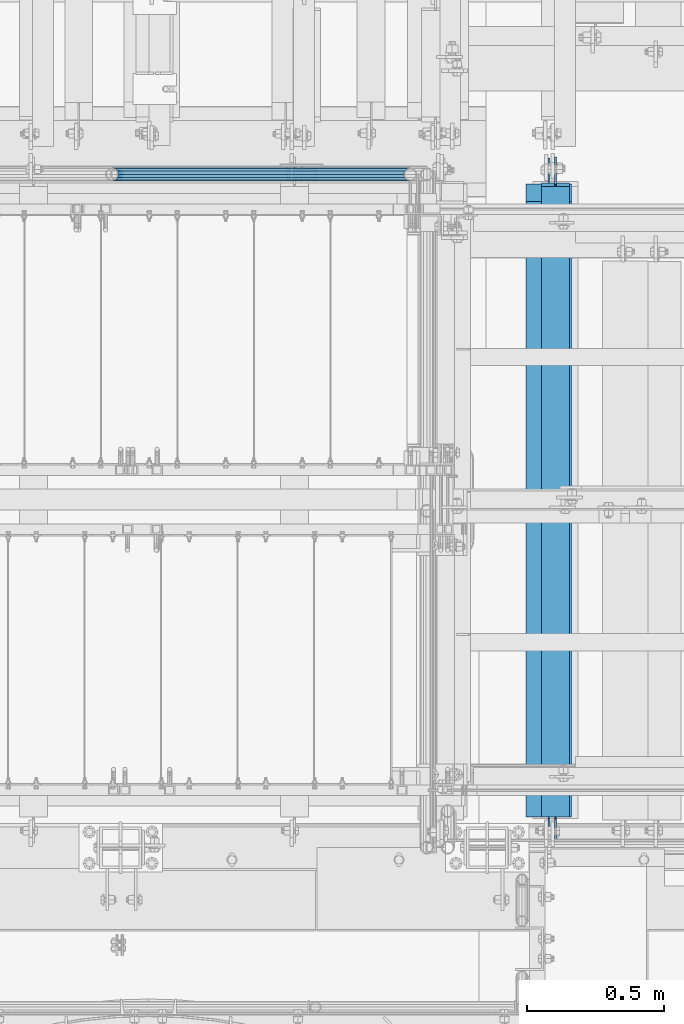
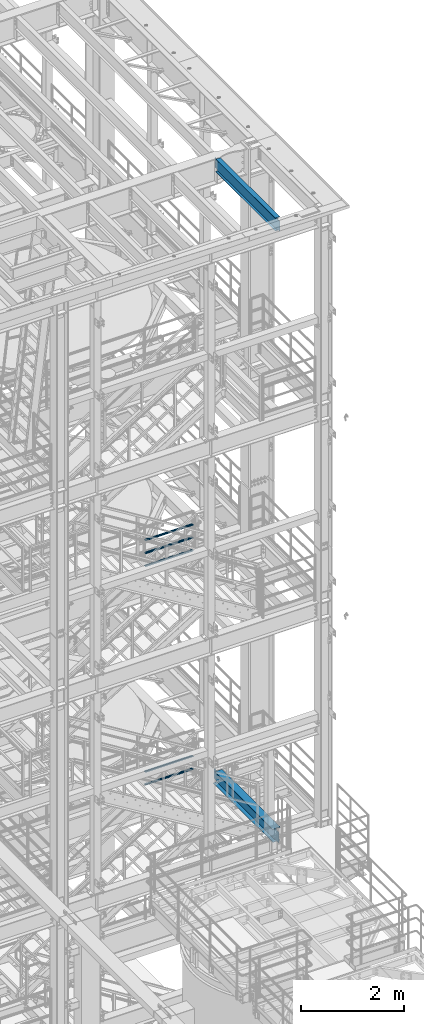
# One storey, part 986 of 1876: 7 beams, 4 elements without a shape of their own.
"""IFC2X3 building model written with IfcOpenShell, lengths in millimetres."""

import ifcopenshell
import ifcopenshell.guid

model = None  # the IFC model being written
_history = None  # IfcOwnerHistory: only IFC2X3 demands one
_inside = {}  # id of a spatial element -> (the spatial element, [elements in it])
_under = {}  # id of a project, library or spatial element -> (it, [spatial elements below it])
_declared = {}  # id of a project -> (the project, [libraries it declares])
_typed = {}  # id of a type object -> (the type object, [elements of that type])
_made_of = {}  # id of a material, layer set ... -> (it, [elements and type objects made of it])


def new_model(schema):
    """Start an empty IFC model of exactly this schema.

    Asked for "IFC4X3", IfcOpenShell would pick the latest addendum, in which some entities
    have other attributes; the version numbers below select the first issue.
    IFC2X3 requires an IfcOwnerHistory on every rooted entity: one is made here for all.
    """
    global model, _history
    if schema == "IFC4X3":
        model = ifcopenshell.file(schema_version=(4, 3, 0, 0))
    else:
        model = ifcopenshell.file(schema=schema)
    _inside.clear()
    _under.clear()
    _declared.clear()
    _typed.clear()
    _made_of.clear()
    _history = None
    if model.schema == "IFC2X3":
        org = make("IfcOrganization", Name="unknown")
        user = make(
            "IfcPersonAndOrganization",
            ThePerson=make("IfcPerson", FamilyName="unknown"),
            TheOrganization=org,
        )
        app = make(
            "IfcApplication",
            ApplicationDeveloper=org,
            Version="unknown",
            ApplicationFullName="unknown",
            ApplicationIdentifier="unknown",
        )
        _history = make(
            "IfcOwnerHistory",
            OwningUser=user,
            OwningApplication=app,
            ChangeAction="ADDED",
            CreationDate=0,
        )
    return model


def make(cls, **values):
    """One entity of the class cls with the attributes given. An attribute that is None is left unset."""
    return model.create_entity(
        cls, **{name: value for name, value in values.items() if value is not None}
    )


def rooted(cls, **values):
    """An entity with a GlobalId (a new one), such as an element, a storey or a relation."""
    return make(cls, GlobalId=ifcopenshell.guid.new(), OwnerHistory=_history, **values)


def si_unit(unit_type, name, prefix=None):
    """IfcSIUnit, for example si_unit("LENGTHUNIT", "METRE", prefix="MILLI")."""
    return make("IfcSIUnit", UnitType=unit_type, Prefix=prefix, Name=name)


def assignment(units):
    """IfcUnitAssignment: the units of a project."""
    return None if units is None else make("IfcUnitAssignment", Units=units)


def point(xyz):
    """IfcCartesianPoint."""
    return None if xyz is None else make("IfcCartesianPoint", Coordinates=xyz)


def direction(xyz):
    """IfcDirection."""
    return None if xyz is None else make("IfcDirection", DirectionRatios=xyz)


def frame(location, z_axis=None, x_axis=None):
    """IfcAxis2Placement3D, a coordinate frame: its origin and axes. An axis left out is left unset."""
    return make(
        "IfcAxis2Placement3D",
        Location=point(location),
        Axis=direction(z_axis),
        RefDirection=direction(x_axis),
    )


def origin_with_axes():
    """The frame at (0, 0, 0) with the z axis (0, 0, 1) and the x axis (1, 0, 0) written out."""
    return frame((0.0, 0.0, 0.0), z_axis=(0.0, 0.0, 1.0), x_axis=(1.0, 0.0, 0.0))


def place(relative_to, where):
    """IfcLocalPlacement: puts the frame where relative to a parent placement (None: the world)."""
    return make(
        "IfcLocalPlacement", PlacementRelTo=relative_to, RelativePlacement=where
    )


def context(
    kind, dimensions, precision=None, world=None, true_north=None, identifier=None
):
    """IfcGeometricRepresentationContext, for example the 3D "Model" context."""
    return make(
        "IfcGeometricRepresentationContext",
        ContextIdentifier=identifier,
        ContextType=kind,
        CoordinateSpaceDimension=dimensions,
        Precision=precision,
        WorldCoordinateSystem=world,
        TrueNorth=true_north,
    )


def subcontext(parent, identifier, kind, view, scale=None):
    """IfcGeometricRepresentationSubContext, for example "Body" below "Model"."""
    return make(
        "IfcGeometricRepresentationSubContext",
        ContextIdentifier=identifier,
        ContextType=kind,
        ParentContext=parent,
        TargetScale=scale,
        TargetView=view,
    )


def project(units=None, contexts=None):
    """IfcProject with its units and contexts."""
    return rooted(
        "IfcProject",
        Name="project",
        RepresentationContexts=contexts,
        UnitsInContext=assignment(units),
    )


def spatial(cls, under=None, at=None, **own):
    """A site, building, storey or space (cls), placed at a placement, below another one or the project."""
    s = rooted(cls, ObjectPlacement=at, **own)
    if under is not None:
        _under.setdefault(under.id(), (under, []))[1].append(s)
    return s


def faces_of(points, faces, orient=None, outer=None):
    """IfcFace entities. A face is a list of loops; a loop is a list of indices into points, from 0.

    orient and outer hold one flag for each loop. By default every Orientation is true, the
    first loop of a face is its IfcFaceOuterBound and the others are IfcFaceBound.
    """
    made = []
    for i, loops in enumerate(faces):
        bounds = []
        for j, loop in enumerate(loops):
            is_outer = j == 0 if outer is None else outer[i][j]
            bounds.append(
                make(
                    "IfcFaceOuterBound" if is_outer else "IfcFaceBound",
                    Bound=make("IfcPolyLoop", Polygon=[points[k] for k in loop]),
                    Orientation=True if orient is None else orient[i][j],
                )
            )
        made.append(make("IfcFace", Bounds=bounds))
    return made


def faceted_brep(points, faces, orient=None, outer=None, voids=None):
    """IfcFacetedBrep: a solid bounded by flat faces; with voids (closed shells), ...WithVoids."""
    shared = [point(p) for p in points]
    hull = make("IfcClosedShell", CfsFaces=faces_of(shared, faces, orient, outer))
    if voids is None:
        return make("IfcFacetedBrep", Outer=hull)
    return make(
        "IfcFacetedBrepWithVoids",
        Outer=hull,
        Voids=[
            make(cls, CfsFaces=faces_of(shared, fs, o, b)) for cls, fs, o, b in voids
        ],
    )


def shape(context_of_items, identifier, shape_type, items):
    """IfcShapeRepresentation: the items that make up one representation, for example the "Body"."""
    return make(
        "IfcShapeRepresentation",
        ContextOfItems=context_of_items,
        RepresentationIdentifier=identifier,
        RepresentationType=shape_type,
        Items=items,
    )


def material(Name=None, Category=None):
    """IfcMaterial."""
    return make("IfcMaterial", Name=Name, Category=Category)


def made_of(thing, what):
    """Note that an element or type object is made of a material, layer set ...; save() writes the relation."""
    if what is not None:
        _made_of.setdefault(what.id(), (what, []))[1].append(thing)
    return thing


def type_object(cls, material=None, **own):
    """A type object (cls), such as IfcWallType, which elements share."""
    return made_of(rooted(cls, **own), material)


def element(
    cls,
    number,
    at=None,
    inside=None,
    cuts=None,
    type_object=None,
    material=None,
    context=None,
    identifier="Body",
    shape_type=None,
    held_by="IfcProductDefinitionShape",
    body=None,
    shapes=None,
    **own,
):
    """One element of the class cls, such as IfcWall. Its Tag is "e" and its number.

    at: its placement. inside: the storey or other place that contains it. cuts: it is an
    opening in that element (IfcRelVoidsElement). A single representation is given by context,
    identifier, shape_type and body (its items); several are given by shapes. held_by: the class
    of the entity that holds the representations. save() writes the other relations.
    """
    e = rooted(cls, Tag="e%d" % number, ObjectPlacement=at, **own)
    if body is not None:
        shapes = [shape(context, identifier, shape_type, body)]
    if shapes is not None:
        e.Representation = make(held_by, Representations=shapes)
    if inside is not None:
        _inside.setdefault(inside.id(), (inside, []))[1].append(e)
    if cuts is not None:
        rooted(
            "IfcRelVoidsElement", RelatingBuildingElement=cuts, RelatedOpeningElement=e
        )
    if type_object is not None:
        _typed.setdefault(type_object.id(), (type_object, []))[1].append(e)
    return made_of(e, material)


def aggregate(whole, parts):
    """IfcRelAggregates: a whole, such as a stair, and the parts it consists of."""
    return rooted("IfcRelAggregates", RelatingObject=whole, RelatedObjects=parts)


def save(model, path):
    """Write the relations noted so far, then the file.

    IfcRelAggregates (storeys below a building ...), IfcRelContainedInSpatialStructure (elements
    in a storey), IfcRelDefinesByType, IfcRelAssociatesMaterial and IfcRelDeclares: one each for
    every whole, place, type object, material and project.
    """
    for whole, parts in _under.values():
        aggregate(whole, parts)
    for where, things in _inside.values():
        rooted(
            "IfcRelContainedInSpatialStructure",
            RelatedElements=things,
            RelatingStructure=where,
        )
    for kind, things in _typed.values():
        rooted("IfcRelDefinesByType", RelatedObjects=things, RelatingType=kind)
    for what, things in _made_of.values():
        rooted("IfcRelAssociatesMaterial", RelatedObjects=things, RelatingMaterial=what)
    for by, libraries in _declared.values():
        rooted("IfcRelDeclares", RelatingContext=by, RelatedDefinitions=libraries)
    model.write(path)


model = new_model("IFC2X3")

# Units and contexts
model_context = context("Model", 3, precision=1e-05, world=origin_with_axes())
body_context = subcontext(model_context, "Body", "Model", "MODEL_VIEW")
ifc_project = project(units=[si_unit("LENGTHUNIT", "METRE", prefix="MILLI"), si_unit("AREAUNIT", "SQUARE_METRE"), si_unit("VOLUMEUNIT", "CUBIC_METRE"), si_unit("MASSUNIT", "GRAM", prefix="KILO"), si_unit("TIMEUNIT", "SECOND"), si_unit("PLANEANGLEUNIT", "RADIAN"), si_unit("SOLIDANGLEUNIT", "STERADIAN"), si_unit("THERMODYNAMICTEMPERATUREUNIT", "DEGREE_CELSIUS"), si_unit("LUMINOUSINTENSITYUNIT", "LUMEN")], contexts=[model_context])

# Site, building, storey
site_placement = place(None, origin_with_axes())
site = spatial("IfcSite", under=ifc_project, at=site_placement, CompositionType="ELEMENT")
building_placement = place(site_placement, origin_with_axes())
building = spatial("IfcBuilding", under=site, at=building_placement, Name="Undefined", CompositionType="ELEMENT")
storey_placement = place(building_placement, origin_with_axes())
storey = spatial("IfcBuildingStorey", under=building, at=storey_placement, Name="Undefined", CompositionType="ELEMENT", Elevation=0.0)

# Assembly, beams
assembly_1_placement = place(storey_placement, origin_with_axes())
assembly_1 = element("IfcElementAssembly", 1, at=assembly_1_placement, inside=storey, Name="RAIL", AssemblyPlace="NOTDEFINED", PredefinedType="RIGID_FRAME")
ifc_material_1 = material()
beam_type_1 = type_object("IfcBeamType", Name="PIPE1-1/2SCH40", PredefinedType="NOTDEFINED")
beam_1_placement = place(assembly_1_placement, frame((6137.27499995291, -4654.55000114568, 13471.525), z_axis=(0.0, 0.0, 1.0), x_axis=(-1.0, 0.0, 0.0)))
beam_1 = element("IfcBeam", 2, at=beam_1_placement, type_object=beam_type_1, material=ifc_material_1, Name="RAIL", ObjectType="PIPE1-1/2SCH40", context=body_context, shape_type="Brep", body=[
    faceted_brep([(1068.12780699489, -12.0649999999996, 20.8971929933177), (1068.12780699489, -12.064999999986, 15.8661214311942), (1067.63437855703, -10.2235000000001, 17.7076214311801), (1064.89499998821, 0.0, 20.4470000000001), (1064.89499998821, 0.0, 24.1299999999992), (1067.63437855703, 10.2235000000001, 17.7076214311801), (1068.12780699489, 12.0650000000132, 15.8661214311669), (1068.12780699489, 12.0649999999996, 20.8971929933177), (1089.02499998822, 24.1300000000001, 0.0), (1076.95999998821, 20.8971929933186, 12.0650000000005), (1076.95999998821, 20.8971929933186, -12.0650000000005), (1073.77042842606, 17.7076214311801, 10.2235000000001), (1076.50980699488, 20.4470000000001, 0.0), (1073.77042842606, 17.7076214311801, -10.2235000000001), (1068.12780699489, 12.0650000000132, -15.8661214311669), (1068.12780699489, 12.0649999999996, -20.8971929933177), (1067.63437855703, 10.2235000000001, -17.7076214311801), (1064.89499998821, 0.0, -20.4470000000001), (1064.89499998821, 0.0, -24.1299999999992), (1068.12780699489, -12.064999999986, -15.8661214311942), (1068.12780699489, -12.0649999999996, -20.8971929933177), (1067.63437855703, -10.2235000000001, -17.7076214311801), (1089.02499998821, -24.1299999999865, 0.0), (1076.95999998821, -20.8971929933186, -12.0650000000005), (1076.95999998821, -20.8971929933186, 12.0650000000005), (1073.77042842609, -17.7076214311801, -10.2235000000001), (1076.50980699491, -20.4470000000001, 0.0), (1073.77042842609, -17.7076214311801, 10.2235000000001), (12.0650000000064, -20.8971929933177, -12.0649999999987), (20.8971929933249, -12.0650000000005, -20.8971929933177), (0.0, 24.1299999999992, 0.0), (12.0650000000064, 20.8971929933177, -12.0649999999987), (12.0650000000064, 20.8971929933177, 12.0649999999987), (20.8971929933249, 12.0650000000005, 20.8971929933177), (24.1300000000064, 0.0, 24.130000000001), (20.8971929933249, 12.0650000000005, -20.8971929933177), (24.1300000000063, 0.0, -24.130000000001), (24.1300000000063, 0.0, -20.4470000000001), (20.8971929933249, -12.0650000000005, -15.8661214311796), (21.3906214311868, -10.2235000000001, -17.7076214311819), (21.3906214311868, 10.2235000000001, -17.7076214311819), (20.8971929933249, 12.0650000000005, -15.8661214311796), (15.2545715621445, 17.7076214311801, -10.2235000000001), (12.5151929933249, 20.4470000000001, 0.0), (15.2545715621445, 17.7076214311801, 10.2235000000001), (20.8971929933249, 12.0650000000005, 15.8661214311796), (21.3906214311868, 10.2235000000001, 17.7076214311819), (24.1300000000064, 0.0, 20.4470000000001), (21.3906214311868, -10.2235000000001, 17.7076214311819), (20.8971929933249, -12.0650000000005, 15.8661214311796), (20.8971929933249, -12.0650000000005, 20.8971929933177), (12.0650000000064, -20.8971929933177, 12.0649999999987), (0.0, -24.1299999999992, 0.0), (15.2545715621445, -17.7076214311801, 10.2235000000001), (12.5151929933249, -20.4470000000001, 0.0), (15.2545715621445, -17.7076214311801, -10.2235000000001)], [[[0, 1, 2, 3, 4]], [[4, 3, 5, 6, 7]], [[8, 9, 10]], [[7, 6, 11, 12, 13, 14, 15, 10, 9]], [[16, 17, 18, 15, 14]], [[19, 20, 18, 17, 21]], [[22, 23, 24]], [[24, 23, 20, 19, 25, 26, 27, 1, 0]], [[28, 29, 20, 23]], [[30, 31, 32]], [[33, 34, 4, 7]], [[32, 33, 7, 9]], [[30, 32, 9, 8]], [[31, 30, 8, 10]], [[35, 31, 10, 15]], [[36, 35, 15, 18]], [[29, 36, 18, 20]], [[37, 36, 29, 38, 39]], [[40, 41, 35, 36, 37]], [[32, 31, 35, 41, 42, 43, 44, 45, 33]], [[33, 45, 46, 47, 34]], [[34, 47, 48, 49, 50]], [[34, 50, 0, 4]], [[50, 51, 24, 0]], [[51, 52, 22, 24]], [[52, 28, 23, 22]], [[51, 28, 52]], [[50, 49, 53, 54, 55, 38, 29, 28, 51]], [[55, 54, 26, 25]], [[21, 39, 38, 55, 25, 19]], [[37, 39, 21, 17]], [[40, 37, 17, 16]], [[42, 41, 40, 16, 14, 13]], [[43, 42, 13, 12]], [[44, 43, 12, 11]], [[5, 46, 45, 44, 11, 6]], [[47, 46, 5, 3]], [[48, 47, 3, 2]], [[53, 49, 48, 2, 1, 27]], [[54, 53, 27, 26]]]),
])
beam_2_placement = place(assembly_1_placement, frame((5048.24999996468, -4654.55000114568, 13776.325), z_axis=(0.0, 0.0, -1.0), x_axis=(1.0, 0.0, 0.0)))
beam_2 = element("IfcBeam", 3, at=beam_2_placement, type_object=beam_type_1, material=ifc_material_1, Name="RAIL", ObjectType="PIPE1-1/2SCH40", context=body_context, shape_type="Brep", body=[
    faceted_brep([(0.0, 24.1299999999992, 0.0), (12.0650000000064, 20.8971929933177, -12.0649999999987), (12.0650000000064, 20.8971929933177, 12.0649999999987), (12.0650000000064, -20.8971929933177, 12.0649999999987), (12.0650000000064, -20.8971929933177, -12.0649999999987), (0.0, -24.1299999999992, 0.0), (20.8971929933249, -12.0650000000005, 20.8971929933177), (20.8971929933249, -12.0650000000005, 15.8661214311796), (15.2545715621445, -17.7076214311801, 10.2235000000001), (12.5151929933249, -20.4470000000001, 0.0), (15.2545715621445, -17.7076214311801, -10.2235000000001), (20.8971929933249, -12.0650000000005, -15.8661214311796), (20.8971929933249, -12.0650000000005, -20.8971929933177), (24.1300000000063, 0.0, -20.4470000000001), (24.1300000000063, 0.0, -24.130000000001), (21.3906214311868, -10.2235000000001, -17.7076214311819), (21.3906214311868, 10.2235000000001, -17.7076214311819), (20.8971929933249, 12.0650000000005, -15.8661214311796), (20.8971929933249, 12.0650000000005, -20.8971929933177), (15.2545715621445, 17.7076214311801, -10.2235000000001), (12.5151929933249, 20.4470000000001, 0.0), (15.2545715621445, 17.7076214311801, 10.2235000000001), (20.8971929933249, 12.0650000000005, 15.8661214311796), (20.8971929933249, 12.0650000000005, 20.8971929933177), (21.3906214311868, 10.2235000000001, 17.7076214311819), (24.1300000000064, 0.0, 20.4470000000001), (24.1300000000064, 0.0, 24.130000000001), (21.3906214311868, -10.2235000000001, 17.7076214311819), (1089.02499998822, 24.1300000000001, 0.0), (1076.95999998821, 20.8971929933186, -12.0650000000005), (1068.12780699489, 12.0649999999996, -20.8971929933177), (1089.02499998821, -24.1299999999865, 0.0), (1076.95999998821, -20.8971929933186, -12.0650000000005), (1076.95999998821, -20.8971929933186, 12.0650000000005), (1068.12780699489, -12.0649999999996, 20.8971929933177), (1068.12780699489, -12.0649999999996, -20.8971929933177), (1064.89499998821, 0.0, -24.1299999999992), (1067.63437855703, 10.2235000000001, -17.7076214311801), (1064.89499998821, 0.0, -20.4470000000001), (1068.12780699489, 12.0650000000132, -15.8661214311669), (1068.12780699489, -12.064999999986, -15.8661214311942), (1067.63437855703, -10.2235000000001, -17.7076214311801), (1073.77042842609, -17.7076214311801, -10.2235000000001), (1076.50980699491, -20.4470000000001, 0.0), (1073.77042842609, -17.7076214311801, 10.2235000000001), (1068.12780699489, -12.064999999986, 15.8661214311942), (1067.63437855703, -10.2235000000001, 17.7076214311801), (1064.89499998821, 0.0, 20.4470000000001), (1064.89499998821, 0.0, 24.1299999999992), (1068.12780699489, 12.0649999999996, 20.8971929933177), (1076.95999998821, 20.8971929933186, 12.0650000000005), (1068.12780699489, 12.0650000000132, 15.8661214311669), (1073.77042842606, 17.7076214311801, 10.2235000000001), (1076.50980699488, 20.4470000000001, 0.0), (1073.77042842606, 17.7076214311801, -10.2235000000001), (1067.63437855703, 10.2235000000001, 17.7076214311801)], [[[0, 1, 2]], [[3, 4, 5]], [[6, 7, 8, 9, 10, 11, 12, 4, 3]], [[13, 14, 12, 11, 15]], [[16, 17, 18, 14, 13]], [[2, 1, 18, 17, 19, 20, 21, 22, 23]], [[23, 22, 24, 25, 26]], [[26, 25, 27, 7, 6]], [[1, 0, 28, 29]], [[18, 1, 29, 30]], [[31, 32, 33]], [[6, 3, 33, 34]], [[3, 5, 31, 33]], [[5, 4, 32, 31]], [[4, 12, 35, 32]], [[12, 14, 36, 35]], [[14, 18, 30, 36]], [[37, 38, 36, 30, 39]], [[40, 35, 36, 38, 41]], [[33, 32, 35, 40, 42, 43, 44, 45, 34]], [[34, 45, 46, 47, 48]], [[26, 6, 34, 48]], [[2, 23, 49, 50]], [[23, 26, 48, 49]], [[0, 2, 50, 28]], [[28, 50, 29]], [[49, 51, 52, 53, 54, 39, 30, 29, 50]], [[48, 47, 55, 51, 49]], [[25, 24, 55, 47]], [[55, 24, 22, 21, 52, 51]], [[21, 20, 53, 52]], [[20, 19, 54, 53]], [[19, 17, 16, 37, 39, 54]], [[16, 13, 38, 37]], [[13, 15, 41, 38]], [[41, 15, 11, 10, 42, 40]], [[10, 9, 43, 42]], [[9, 8, 44, 43]], [[8, 7, 27, 46, 45, 44]], [[27, 25, 47, 46]]]),
])
beam_3_placement = place(assembly_1_placement, frame((5048.24999996468, -4654.55000114568, 14081.125), z_axis=(0.0, 0.0, -1.0), x_axis=(1.0, 0.0, 0.0)))
beam_3 = element("IfcBeam", 4, at=beam_3_placement, type_object=beam_type_1, material=ifc_material_1, Name="RAIL", ObjectType="PIPE1-1/2SCH40", context=body_context, shape_type="Brep", body=[
    faceted_brep([(0.0, 24.1299999999992, 0.0), (12.0650000000064, 20.8971929933177, -12.0649999999987), (12.0650000000064, 20.8971929933177, 12.0649999999987), (12.0650000000064, -20.8971929933177, 12.0649999999987), (12.0650000000064, -20.8971929933177, -12.0649999999987), (0.0, -24.1299999999992, 0.0), (20.8971929933249, -12.0650000000005, 20.8971929933177), (20.8971929933249, -12.0650000000005, 15.8661214311796), (15.2545715621445, -17.7076214311801, 10.2235000000001), (12.5151929933249, -20.4470000000001, 0.0), (15.2545715621445, -17.7076214311801, -10.2235000000001), (20.8971929933249, -12.0650000000005, -15.8661214311796), (20.8971929933249, -12.0650000000005, -20.8971929933177), (24.1300000000063, 0.0, -20.4470000000001), (24.1300000000063, 0.0, -24.130000000001), (21.3906214311868, -10.2235000000001, -17.7076214311819), (21.3906214311868, 10.2235000000001, -17.7076214311819), (20.8971929933249, 12.0650000000005, -15.8661214311796), (20.8971929933249, 12.0650000000005, -20.8971929933177), (15.2545715621445, 17.7076214311801, -10.2235000000001), (12.5151929933249, 20.4470000000001, 0.0), (15.2545715621445, 17.7076214311801, 10.2235000000001), (20.8971929933249, 12.0650000000005, 15.8661214311796), (20.8971929933249, 12.0650000000005, 20.8971929933177), (21.3906214311868, 10.2235000000001, 17.7076214311819), (24.1300000000064, 0.0, 20.4470000000001), (24.1300000000064, 0.0, 24.130000000001), (21.3906214311868, -10.2235000000001, 17.7076214311819), (1089.02499998822, 24.1300000000001, 0.0), (1076.95999998821, 20.8971929933186, -12.0650000000005), (1068.12780699489, 12.0649999999996, -20.8971929933177), (1089.02499998821, -24.1299999999865, 0.0), (1076.95999998821, -20.8971929933186, -12.0650000000005), (1076.95999998821, -20.8971929933186, 12.0650000000005), (1068.12780699489, -12.0649999999996, 20.8971929933177), (1068.12780699489, -12.0649999999996, -20.8971929933177), (1064.89499998821, 0.0, -24.1299999999992), (1067.63437855703, 10.2235000000001, -17.7076214311801), (1064.89499998821, 0.0, -20.4470000000001), (1068.12780699489, 12.0650000000132, -15.8661214311669), (1068.12780699489, -12.064999999986, -15.8661214311942), (1067.63437855703, -10.2235000000001, -17.7076214311801), (1073.77042842609, -17.7076214311801, -10.2235000000001), (1076.50980699491, -20.4470000000001, 0.0), (1073.77042842609, -17.7076214311801, 10.2235000000001), (1068.12780699489, -12.064999999986, 15.8661214311942), (1067.63437855703, -10.2235000000001, 17.7076214311801), (1064.89499998821, 0.0, 20.4470000000001), (1064.89499998821, 0.0, 24.1299999999992), (1068.12780699489, 12.0649999999996, 20.8971929933177), (1076.95999998821, 20.8971929933186, 12.0650000000005), (1068.12780699489, 12.0650000000132, 15.8661214311669), (1073.77042842606, 17.7076214311801, 10.2235000000001), (1076.50980699488, 20.4470000000001, 0.0), (1073.77042842606, 17.7076214311801, -10.2235000000001), (1067.63437855703, 10.2235000000001, 17.7076214311801)], [[[0, 1, 2]], [[3, 4, 5]], [[6, 7, 8, 9, 10, 11, 12, 4, 3]], [[13, 14, 12, 11, 15]], [[16, 17, 18, 14, 13]], [[2, 1, 18, 17, 19, 20, 21, 22, 23]], [[23, 22, 24, 25, 26]], [[26, 25, 27, 7, 6]], [[1, 0, 28, 29]], [[18, 1, 29, 30]], [[31, 32, 33]], [[6, 3, 33, 34]], [[3, 5, 31, 33]], [[5, 4, 32, 31]], [[4, 12, 35, 32]], [[12, 14, 36, 35]], [[14, 18, 30, 36]], [[37, 38, 36, 30, 39]], [[40, 35, 36, 38, 41]], [[33, 32, 35, 40, 42, 43, 44, 45, 34]], [[34, 45, 46, 47, 48]], [[26, 6, 34, 48]], [[2, 23, 49, 50]], [[23, 26, 48, 49]], [[0, 2, 50, 28]], [[28, 50, 29]], [[49, 51, 52, 53, 54, 39, 30, 29, 50]], [[48, 47, 55, 51, 49]], [[25, 24, 55, 47]], [[55, 24, 22, 21, 52, 51]], [[21, 20, 53, 52]], [[20, 19, 54, 53]], [[19, 17, 16, 37, 39, 54]], [[16, 13, 38, 37]], [[13, 15, 41, 38]], [[41, 15, 11, 10, 42, 40]], [[10, 9, 43, 42]], [[9, 8, 44, 43]], [[8, 7, 27, 46, 45, 44]], [[27, 25, 47, 46]]]),
])
aggregate(assembly_1, [beam_1, beam_2, beam_3])

assembly_2_placement = place(storey_placement, origin_with_axes())
assembly_2 = element("IfcElementAssembly", 5, at=assembly_2_placement, inside=storey, Name="RAIL", AssemblyPlace="NOTDEFINED", PredefinedType="RIGID_FRAME")
beam_4_placement = place(assembly_2_placement, frame((6137.27499995291, -4654.55000114554, 8315.325), z_axis=(0.0, 0.0, 1.0), x_axis=(-1.0, 0.0, 0.0)))
beam_4 = element("IfcBeam", 6, at=beam_4_placement, type_object=beam_type_1, material=ifc_material_1, Name="RAIL", ObjectType="PIPE1-1/2SCH40", context=body_context, shape_type="Brep", body=[
    faceted_brep([(1068.12780699489, -12.0649999999996, 20.8971929933177), (1068.12780699489, -12.064999999986, 15.8661214311942), (1067.63437855703, -10.2235000000001, 17.7076214311801), (1064.89499998821, 0.0, 20.4470000000001), (1064.89499998821, 0.0, 24.1299999999992), (1067.63437855703, 10.2235000000001, 17.7076214311801), (1068.12780699489, 12.0650000000132, 15.8661214311669), (1068.12780699489, 12.0649999999996, 20.8971929933177), (1089.02499998822, 24.1300000000001, 0.0), (1076.95999998821, 20.8971929933186, 12.0650000000005), (1076.95999998821, 20.8971929933186, -12.0650000000005), (1073.77042842606, 17.7076214311801, 10.2235000000001), (1076.50980699488, 20.4470000000001, 0.0), (1073.77042842606, 17.7076214311801, -10.2235000000001), (1068.12780699489, 12.0650000000132, -15.8661214311669), (1068.12780699489, 12.0649999999996, -20.8971929933177), (1067.63437855703, 10.2235000000001, -17.7076214311801), (1064.89499998821, 0.0, -20.4470000000001), (1064.89499998821, 0.0, -24.1299999999992), (1068.12780699489, -12.064999999986, -15.8661214311942), (1068.12780699489, -12.0649999999996, -20.8971929933177), (1067.63437855703, -10.2235000000001, -17.7076214311801), (1089.02499998821, -24.1299999999865, 0.0), (1076.95999998821, -20.8971929933186, -12.0650000000005), (1076.95999998821, -20.8971929933186, 12.0650000000005), (1073.77042842609, -17.7076214311801, -10.2235000000001), (1076.50980699491, -20.4470000000001, 0.0), (1073.77042842609, -17.7076214311801, 10.2235000000001), (12.0650000000064, -20.8971929933177, -12.0649999999987), (20.8971929933249, -12.0650000000005, -20.8971929933177), (0.0, 24.1299999999992, 0.0), (12.0650000000064, 20.8971929933177, -12.0649999999987), (12.0650000000064, 20.8971929933177, 12.0649999999987), (20.8971929933249, 12.0650000000005, 20.8971929933177), (24.1300000000064, 0.0, 24.130000000001), (20.8971929933249, 12.0650000000005, -20.8971929933177), (24.1300000000063, 0.0, -24.130000000001), (24.1300000000063, 0.0, -20.4470000000001), (20.8971929933249, -12.0650000000005, -15.8661214311796), (21.3906214311868, -10.2235000000001, -17.7076214311819), (21.3906214311868, 10.2235000000001, -17.7076214311819), (20.8971929933249, 12.0650000000005, -15.8661214311796), (15.2545715621445, 17.7076214311801, -10.2235000000001), (12.5151929933249, 20.4470000000001, 0.0), (15.2545715621445, 17.7076214311801, 10.2235000000001), (20.8971929933249, 12.0650000000005, 15.8661214311796), (21.3906214311868, 10.2235000000001, 17.7076214311819), (24.1300000000064, 0.0, 20.4470000000001), (21.3906214311868, -10.2235000000001, 17.7076214311819), (20.8971929933249, -12.0650000000005, 15.8661214311796), (20.8971929933249, -12.0650000000005, 20.8971929933177), (12.0650000000064, -20.8971929933177, 12.0649999999987), (0.0, -24.1299999999992, 0.0), (15.2545715621445, -17.7076214311801, 10.2235000000001), (12.5151929933249, -20.4470000000001, 0.0), (15.2545715621445, -17.7076214311801, -10.2235000000001)], [[[0, 1, 2, 3, 4]], [[4, 3, 5, 6, 7]], [[8, 9, 10]], [[7, 6, 11, 12, 13, 14, 15, 10, 9]], [[16, 17, 18, 15, 14]], [[19, 20, 18, 17, 21]], [[22, 23, 24]], [[24, 23, 20, 19, 25, 26, 27, 1, 0]], [[28, 29, 20, 23]], [[30, 31, 32]], [[33, 34, 4, 7]], [[32, 33, 7, 9]], [[30, 32, 9, 8]], [[31, 30, 8, 10]], [[35, 31, 10, 15]], [[36, 35, 15, 18]], [[29, 36, 18, 20]], [[37, 36, 29, 38, 39]], [[40, 41, 35, 36, 37]], [[32, 31, 35, 41, 42, 43, 44, 45, 33]], [[33, 45, 46, 47, 34]], [[34, 47, 48, 49, 50]], [[34, 50, 0, 4]], [[50, 51, 24, 0]], [[51, 52, 22, 24]], [[52, 28, 23, 22]], [[51, 28, 52]], [[50, 49, 53, 54, 55, 38, 29, 28, 51]], [[55, 54, 26, 25]], [[21, 39, 38, 55, 25, 19]], [[37, 39, 21, 17]], [[40, 37, 17, 16]], [[42, 41, 40, 16, 14, 13]], [[43, 42, 13, 12]], [[44, 43, 12, 11]], [[5, 46, 45, 44, 11, 6]], [[47, 46, 5, 3]], [[48, 47, 3, 2]], [[53, 49, 48, 2, 1, 27]], [[54, 53, 27, 26]]]),
])
beam_5_placement = place(assembly_2_placement, frame((5048.24999996468, -4654.55000114554, 8620.125), z_axis=(0.0, 0.0, -1.0), x_axis=(1.0, 0.0, 0.0)))
beam_5 = element("IfcBeam", 7, at=beam_5_placement, type_object=beam_type_1, material=ifc_material_1, Name="RAIL", ObjectType="PIPE1-1/2SCH40", context=body_context, shape_type="Brep", body=[
    faceted_brep([(0.0, 24.1299999999992, 0.0), (12.0650000000064, 20.8971929933177, -12.0649999999987), (12.0650000000064, 20.8971929933177, 12.0649999999987), (12.0650000000064, -20.8971929933177, 12.0649999999987), (12.0650000000064, -20.8971929933177, -12.0649999999987), (0.0, -24.1299999999992, 0.0), (20.8971929933249, -12.0650000000005, 20.8971929933177), (20.8971929933249, -12.0650000000005, 15.8661214311796), (15.2545715621445, -17.7076214311801, 10.2235000000001), (12.5151929933249, -20.4470000000001, 0.0), (15.2545715621445, -17.7076214311801, -10.2235000000001), (20.8971929933249, -12.0650000000005, -15.8661214311796), (20.8971929933249, -12.0650000000005, -20.8971929933177), (24.1300000000063, 0.0, -20.4470000000001), (24.1300000000063, 0.0, -24.130000000001), (21.3906214311868, -10.2235000000001, -17.7076214311819), (21.3906214311868, 10.2235000000001, -17.7076214311819), (20.8971929933249, 12.0650000000005, -15.8661214311796), (20.8971929933249, 12.0650000000005, -20.8971929933177), (15.2545715621445, 17.7076214311801, -10.2235000000001), (12.5151929933249, 20.4470000000001, 0.0), (15.2545715621445, 17.7076214311801, 10.2235000000001), (20.8971929933249, 12.0650000000005, 15.8661214311796), (20.8971929933249, 12.0650000000005, 20.8971929933177), (21.3906214311868, 10.2235000000001, 17.7076214311819), (24.1300000000064, 0.0, 20.4470000000001), (24.1300000000064, 0.0, 24.130000000001), (21.3906214311868, -10.2235000000001, 17.7076214311819), (1089.02499998822, 24.1300000000001, 0.0), (1076.95999998821, 20.8971929933186, -12.0650000000005), (1068.12780699489, 12.0649999999996, -20.8971929933177), (1089.02499998821, -24.1299999999865, 0.0), (1076.95999998821, -20.8971929933186, -12.0650000000005), (1076.95999998821, -20.8971929933186, 12.0650000000005), (1068.12780699489, -12.0649999999996, 20.8971929933177), (1068.12780699489, -12.0649999999996, -20.8971929933177), (1064.89499998821, 0.0, -24.1299999999992), (1067.63437855703, 10.2235000000001, -17.7076214311801), (1064.89499998821, 0.0, -20.4470000000001), (1068.12780699489, 12.0650000000132, -15.8661214311669), (1068.12780699489, -12.064999999986, -15.8661214311942), (1067.63437855703, -10.2235000000001, -17.7076214311801), (1073.77042842609, -17.7076214311801, -10.2235000000001), (1076.50980699491, -20.4470000000001, 0.0), (1073.77042842609, -17.7076214311801, 10.2235000000001), (1068.12780699489, -12.064999999986, 15.8661214311942), (1067.63437855703, -10.2235000000001, 17.7076214311801), (1064.89499998821, 0.0, 20.4470000000001), (1064.89499998821, 0.0, 24.1299999999992), (1068.12780699489, 12.0649999999996, 20.8971929933177), (1076.95999998821, 20.8971929933186, 12.0650000000005), (1068.12780699489, 12.0650000000132, 15.8661214311669), (1073.77042842606, 17.7076214311801, 10.2235000000001), (1076.50980699488, 20.4470000000001, 0.0), (1073.77042842606, 17.7076214311801, -10.2235000000001), (1067.63437855703, 10.2235000000001, 17.7076214311801)], [[[0, 1, 2]], [[3, 4, 5]], [[6, 7, 8, 9, 10, 11, 12, 4, 3]], [[13, 14, 12, 11, 15]], [[16, 17, 18, 14, 13]], [[2, 1, 18, 17, 19, 20, 21, 22, 23]], [[23, 22, 24, 25, 26]], [[26, 25, 27, 7, 6]], [[1, 0, 28, 29]], [[18, 1, 29, 30]], [[31, 32, 33]], [[6, 3, 33, 34]], [[3, 5, 31, 33]], [[5, 4, 32, 31]], [[4, 12, 35, 32]], [[12, 14, 36, 35]], [[14, 18, 30, 36]], [[37, 38, 36, 30, 39]], [[40, 35, 36, 38, 41]], [[33, 32, 35, 40, 42, 43, 44, 45, 34]], [[34, 45, 46, 47, 48]], [[26, 6, 34, 48]], [[2, 23, 49, 50]], [[23, 26, 48, 49]], [[0, 2, 50, 28]], [[28, 50, 29]], [[49, 51, 52, 53, 54, 39, 30, 29, 50]], [[48, 47, 55, 51, 49]], [[25, 24, 55, 47]], [[55, 24, 22, 21, 52, 51]], [[21, 20, 53, 52]], [[20, 19, 54, 53]], [[19, 17, 16, 37, 39, 54]], [[16, 13, 38, 37]], [[13, 15, 41, 38]], [[41, 15, 11, 10, 42, 40]], [[10, 9, 43, 42]], [[9, 8, 44, 43]], [[8, 7, 27, 46, 45, 44]], [[27, 25, 47, 46]]]),
])
aggregate(assembly_2, [beam_4, beam_5])

# Assembly, beam
assembly_3_placement = place(storey_placement, origin_with_axes())
assembly_3 = element("IfcElementAssembly", 8, at=assembly_3_placement, inside=storey, Name="BEAM", AssemblyPlace="NOTDEFINED", PredefinedType="RIGID_FRAME")
ifc_material_2 = material(Name="STEEL/A992")
beam_type_2 = type_object("IfcBeamType", Name="W12X16", PredefinedType="NOTDEFINED")
beam_6_placement = place(assembly_3_placement, frame((6667.5, -7112.0, 22402.8), z_axis=(0.0, 0.0, 1.0), x_axis=(0.0, 1.0, 0.0)))
beam_6 = element("IfcBeam", 9, at=beam_6_placement, type_object=beam_type_2, material=ifc_material_2, Name="BEAM", ObjectType="W12X16", context=body_context, shape_type="Brep", body=[
    faceted_brep([(17.4625000000005, -3.17500000000018, -126.999999999999), (17.4625000000005, 3.17500000000018, -126.999999999999), (100.012500190734, 3.17500000000018, -126.999999999999), (100.012500190734, -3.17500000000018, -126.999999999999), (104.87257970878, 3.17500000000018, -127.966729922587), (104.87257970878, -3.17500000000018, -127.966729922587), (108.992756176934, 3.17500000000018, -130.719743823065), (108.992756176934, -3.17500000000018, -130.719743823065), (111.745770077412, 3.17500000000018, -134.839920291219), (111.745770077412, -3.17500000000018, -134.839920291219), (112.7125, -3.17500000000018, -139.699999809264), (112.7125, 3.17500000000018, -139.699999809264), (112.712500000001, 3.17500000000018, -146.049999999999), (112.7125, 50.8000000000002, -146.05), (112.7125, 50.8000000000002, -152.4), (112.7125, -50.8000000000002, -152.4), (112.7125, -50.8000000000002, -146.05), (112.712500000001, -3.17500000000018, -146.049999999999), (2412.20625, 50.8000000000002, 146.049999999999), (2412.20625, 3.17500000000018, 146.049999999999), (112.712500000001, 3.17500000000018, 146.05), (112.712500000001, 50.8000000000002, 146.049999999999), (100.012500190735, -3.17500000000018, 114.299999999996), (100.012500190735, 3.17500000000018, 114.299999999996), (17.4624999999996, 3.17500000000018, 114.299999999996), (17.4624999999996, -3.17500000000018, 114.299999999996), (104.872579708781, -3.17500000000018, 115.266729922583), (104.872579708781, 3.17500000000018, 115.266729922583), (108.992756176935, -3.17500000000018, 118.019743823061), (108.992756176935, 3.17500000000018, 118.019743823061), (111.745770077413, -3.17500000000018, 122.139920291214), (111.745770077413, 3.17500000000018, 122.139920291214), (112.712500000001, -3.17500000000018, 126.999999809261), (112.712500000001, 3.17500000000018, 126.999999809261), (2412.20625, -50.8000000000002, 152.400000000001), (2412.20625, 50.8000000000002, 152.400000000001), (112.712500000001, 50.8000000000002, 152.400000000001), (112.712500000001, -50.8000000000002, 152.400000000001), (2412.20625, -50.8000000000002, 146.049999999999), (112.712500000001, -50.8000000000002, 146.049999999999), (2412.20625, -3.17500000000018, 146.049999999999), (112.712500000001, -3.17500000000018, 146.05), (2412.20625, -3.17500000000018, 126.999999809268), (2412.20625, 3.17500000000018, 126.999999809268), (2413.17297992259, -3.17500000000018, 122.139920291222), (2413.17297992259, 3.17500000000018, 122.139920291222), (2415.92599382307, -3.17500000000018, 118.019743823068), (2415.92599382307, 3.17500000000018, 118.019743823068), (2420.04617029122, -3.17500000000018, 115.26672992259), (2420.04617029122, 3.17500000000018, 115.26672992259), (2424.90624980927, -3.17500000000018, 114.300000000003), (2424.90624980927, 3.17500000000018, 114.300000000003), (2520.15625, -3.17500000000018, 114.300000000003), (2520.15625, 3.17500000000018, 114.300000000003), (2520.15625, -3.17500000000018, -126.999999999996), (2520.15625, 3.17500000000018, -126.999999999996), (2437.60624980927, -3.17500000000018, -126.999999999996), (2437.60624980927, 3.17500000000018, -126.999999999996), (2432.74617029122, -3.17500000000018, -127.966729922584), (2432.74617029122, 3.17500000000018, -127.966729922584), (2428.62599382307, -3.17500000000018, -130.719743823061), (2428.62599382307, 3.17500000000018, -130.719743823061), (2425.87297992259, -3.17500000000018, -134.839920291215), (2425.87297992259, 3.17500000000018, -134.839920291215), (2424.90625, -3.17500000000018, -139.699999809261), (2424.90625, 3.17500000000018, -139.699999809261), (2424.90625, -3.17500000000018, -146.049999999999), (2424.90625, -50.8000000000002, -146.049999999999), (2424.90625, -50.8000000000002, -152.400000000001), (2424.90625, 50.8000000000002, -152.400000000001), (2424.90625, 50.8000000000002, -146.049999999999), (2424.90625, 3.17500000000018, -146.049999999999)], [[[0, 1, 2, 3]], [[3, 2, 4, 5]], [[5, 4, 6, 7]], [[7, 6, 8, 9]], [[10, 11, 12, 13, 14, 15, 16, 17]], [[9, 8, 11, 10]], [[18, 19, 20, 21]], [[22, 23, 24, 25]], [[26, 27, 23, 22]], [[28, 29, 27, 26]], [[30, 31, 29, 28]], [[32, 33, 31, 30]], [[34, 35, 36, 37]], [[38, 34, 37, 39]], [[40, 38, 39, 41]], [[37, 36, 21, 20, 33, 32, 41, 39]], [[35, 18, 21, 36]], [[34, 38, 40, 42, 43, 19, 18, 35]], [[44, 45, 43, 42]], [[46, 47, 45, 44]], [[48, 49, 47, 46]], [[50, 51, 49, 48]], [[52, 53, 51, 50]], [[53, 52, 54, 55]], [[54, 56, 57, 55]], [[58, 59, 57, 56]], [[60, 61, 59, 58]], [[62, 63, 61, 60]], [[64, 65, 63, 62]], [[66, 67, 68, 69, 70, 71, 65, 64]], [[67, 66, 17, 16]], [[68, 67, 16, 15]], [[69, 68, 15, 14]], [[70, 69, 14, 13]], [[71, 70, 13, 12]], [[6, 4, 2, 1, 24, 23, 27, 29, 31, 33, 20, 19, 43, 45, 47, 49, 51, 53, 55, 57, 59, 61, 63, 65, 71, 12, 11, 8]], [[25, 24, 1, 0]], [[66, 64, 62, 60, 58, 56, 54, 52, 50, 48, 46, 44, 42, 40, 41, 32, 30, 28, 26, 22, 25, 0, 3, 5, 7, 9, 10, 17]]]),
])
aggregate(assembly_3, [beam_6])

assembly_4_placement = place(storey_placement, origin_with_axes())
assembly_4 = element("IfcElementAssembly", 10, at=assembly_4_placement, inside=storey, Name="BEAM", AssemblyPlace="NOTDEFINED", PredefinedType="RIGID_FRAME")
beam_type_3 = type_object("IfcBeamType", Name="W12X30", PredefinedType="NOTDEFINED")
beam_7_placement = place(assembly_4_placement, frame((6642.496875, -7112.0, 7996.2375), z_axis=(0.0, 0.0, 1.0), x_axis=(0.0, 1.0, 0.0)))
beam_7 = element("IfcBeam", 11, at=beam_7_placement, type_object=beam_type_3, material=ifc_material_2, Name="BEAM", ObjectType="W12X30", context=body_context, shape_type="Brep", body=[
    faceted_brep([(17.4624999999996, -3.17500000000018, -131.762500000004), (17.4624999999996, 3.17500000000018, -131.762500000004), (100.012500190735, 3.17500000000018, -131.762500000001), (100.012500190735, -3.17500000000018, -131.762500000001), (104.872579708781, 3.17500000000018, -132.729229922588), (104.872579708781, -3.17500000000018, -132.729229922588), (108.992756176935, 3.17500000000018, -135.482243823066), (108.992756176935, -3.17500000000018, -135.482243823066), (111.745770077413, 3.17500000000018, -139.602420291219), (111.745770077413, -3.17500000000018, -139.602420291219), (112.712500000001, -3.17500000000018, -144.462499809266), (112.712500000001, 3.17500000000018, -144.462499809266), (112.712500000001, 3.17500000000018, -146.049999999999), (112.712500000001, 82.5500000000002, -146.049999999999), (112.712500000001, 82.5500000000002, -157.1625), (112.712500000001, -82.5500000000002, -157.1625), (112.712500000001, -82.5500000000002, -146.049999999999), (112.712500000001, -3.17500000000018, -146.049999999999), (2358.23125, 82.5500000000002, 146.05), (2358.23125, 3.17500000000018, 146.05), (112.712500000001, 3.17500000000018, 146.05), (112.712500000001, 82.5500000000002, 146.05), (100.012500190735, -3.17500000000018, 119.062500000001), (100.012500190735, 3.17500000000018, 119.062500000001), (17.4624999999996, 3.17500000000018, 119.0625), (17.4624999999996, -3.17500000000018, 119.0625), (104.872579708781, -3.17500000000018, 120.029229922588), (104.872579708781, 3.17500000000018, 120.029229922588), (108.992756176935, -3.17500000000018, 122.782243823067), (108.992756176935, 3.17500000000018, 122.782243823067), (111.745770077413, -3.17500000000018, 126.902420291221), (111.745770077413, 3.17500000000018, 126.902420291221), (112.712500000001, -3.17500000000018, 131.762499809266), (112.712500000001, 3.17500000000018, 131.762499809266), (2358.23125, -82.5500000000002, 157.1625), (2358.23125, 82.5500000000002, 157.1625), (112.712500000001, 82.5500000000002, 157.1625), (112.712500000001, -82.5500000000002, 157.1625), (2358.23125, -82.5500000000002, 146.05), (112.712500000001, -82.5500000000002, 146.05), (2358.23125, -3.17500000000018, 146.05), (112.712500000001, -3.17500000000018, 146.05), (2358.23125, -3.17500000000018, 119.062499809265), (2358.23125, 3.17500000000018, 119.062499809265), (2359.19797992259, -3.17500000000018, 114.20242029122), (2359.19797992259, 3.17500000000018, 114.20242029122), (2361.95099382307, -3.17500000000018, 110.082243823066), (2361.95099382307, 3.17500000000018, 110.082243823066), (2366.07117029122, -3.17500000000018, 107.329229922588), (2366.07117029122, 3.17500000000018, 107.329229922588), (2370.93124980927, -3.17500000000018, 106.3625), (2370.93124980927, 3.17500000000018, 106.3625), (2516.98125, -3.17500000000018, 106.3625), (2516.98125, 3.17500000000018, 106.3625), (2516.98125, -3.17500000000018, -131.7625), (2516.98125, 3.17500000000018, -131.7625), (2434.43124980927, -3.17500000000018, -131.7625), (2434.43124980927, 3.17500000000018, -131.7625), (2429.57117029122, -3.17500000000018, -132.729229922587), (2429.57117029122, 3.17500000000018, -132.729229922587), (2425.45099382307, -3.17500000000018, -135.482243823066), (2425.45099382307, 3.17500000000018, -135.482243823066), (2422.69797992259, -3.17500000000018, -139.602420291219), (2422.69797992259, 3.17500000000018, -139.602420291219), (2421.73125, -3.17500000000018, -144.462499809265), (2421.73125, 3.17500000000018, -144.462499809265), (2421.73125, -3.17500000000018, -146.05), (2421.73125, -82.5500000000002, -146.05), (2421.73125, -82.5500000000002, -157.1625), (2421.73125, 82.5500000000002, -157.1625), (2421.73125, 82.5500000000002, -146.05), (2421.73125, 3.17500000000018, -146.05)], [[[0, 1, 2, 3]], [[3, 2, 4, 5]], [[5, 4, 6, 7]], [[7, 6, 8, 9]], [[10, 11, 12, 13, 14, 15, 16, 17]], [[9, 8, 11, 10]], [[18, 19, 20, 21]], [[22, 23, 24, 25]], [[26, 27, 23, 22]], [[28, 29, 27, 26]], [[30, 31, 29, 28]], [[32, 33, 31, 30]], [[34, 35, 36, 37]], [[38, 34, 37, 39]], [[40, 38, 39, 41]], [[37, 36, 21, 20, 33, 32, 41, 39]], [[35, 18, 21, 36]], [[34, 38, 40, 42, 43, 19, 18, 35]], [[44, 45, 43, 42]], [[46, 47, 45, 44]], [[48, 49, 47, 46]], [[50, 51, 49, 48]], [[52, 53, 51, 50]], [[53, 52, 54, 55]], [[54, 56, 57, 55]], [[58, 59, 57, 56]], [[60, 61, 59, 58]], [[62, 63, 61, 60]], [[64, 65, 63, 62]], [[66, 67, 68, 69, 70, 71, 65, 64]], [[67, 66, 17, 16]], [[68, 67, 16, 15]], [[69, 68, 15, 14]], [[70, 69, 14, 13]], [[71, 70, 13, 12]], [[6, 4, 2, 1, 24, 23, 27, 29, 31, 33, 20, 19, 43, 45, 47, 49, 51, 53, 55, 57, 59, 61, 63, 65, 71, 12, 11, 8]], [[25, 24, 1, 0]], [[66, 64, 62, 60, 58, 56, 54, 52, 50, 48, 46, 44, 42, 40, 41, 32, 30, 28, 26, 22, 25, 0, 3, 5, 7, 9, 10, 17]]]),
])
aggregate(assembly_4, [beam_7])

save(model, "model.ifc")
